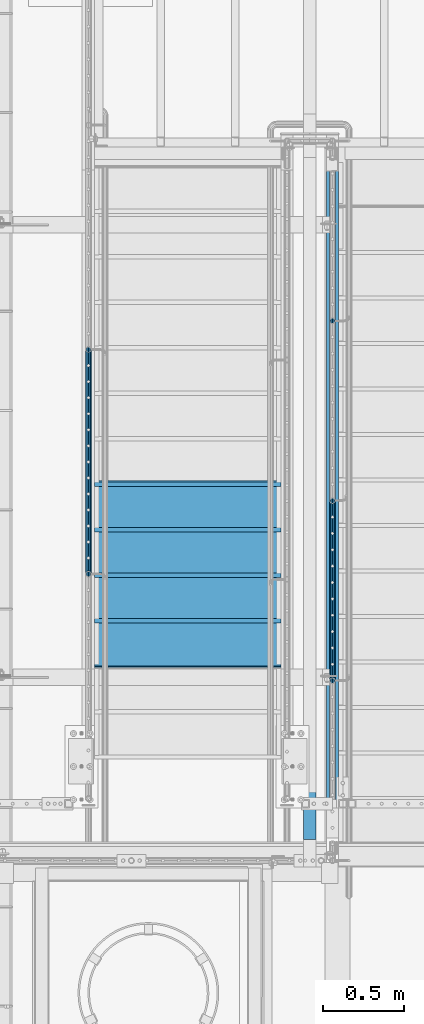
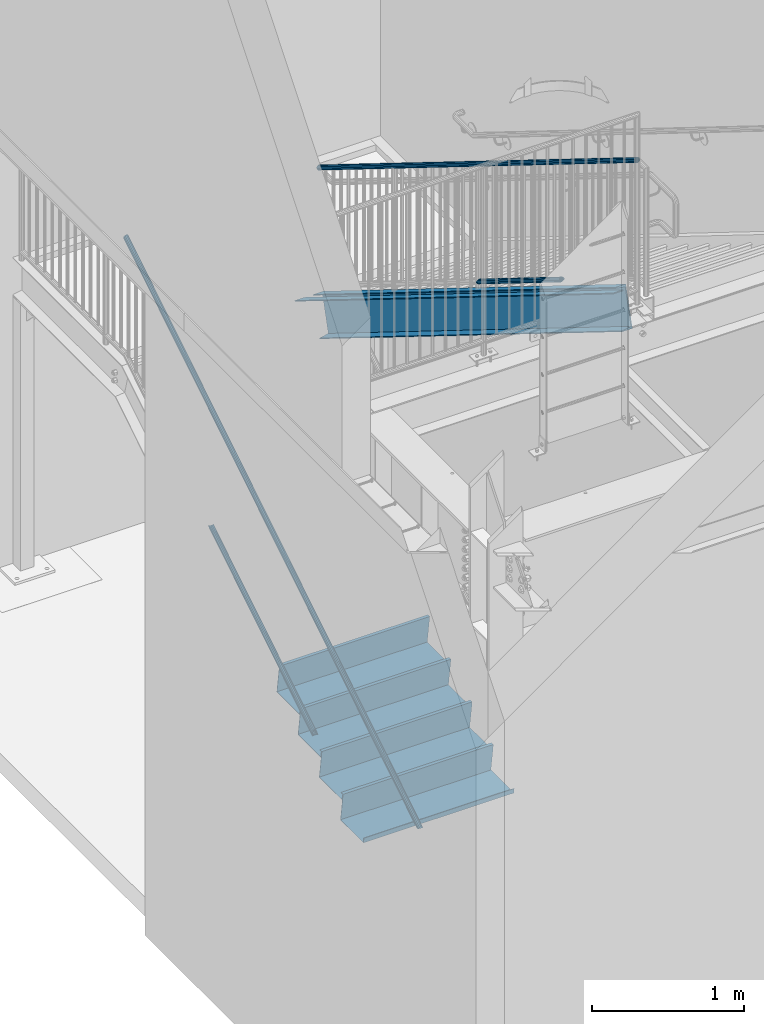
# One storey, part 1090 of 1763: 6 members, 4 beams, 5 elements without a shape of their own.
"""IFC2X3 building model written with IfcOpenShell, lengths in millimetres."""

from ifc_helpers import new_model, si_unit, frame, origin_with_axes, place, context, subcontext, project, spatial, faceted_brep, material, type_object, element, aggregate, save


model = new_model("IFC2X3")

# Units and contexts
model_context = context("Model", 3, precision=1e-05, world=origin_with_axes())
body_context = subcontext(model_context, "Body", "Model", "MODEL_VIEW")
ifc_project = project(units=[si_unit("LENGTHUNIT", "METRE", prefix="MILLI"), si_unit("AREAUNIT", "SQUARE_METRE"), si_unit("VOLUMEUNIT", "CUBIC_METRE"), si_unit("MASSUNIT", "GRAM", prefix="KILO"), si_unit("TIMEUNIT", "SECOND"), si_unit("PLANEANGLEUNIT", "RADIAN"), si_unit("SOLIDANGLEUNIT", "STERADIAN"), si_unit("THERMODYNAMICTEMPERATUREUNIT", "DEGREE_CELSIUS"), si_unit("LUMINOUSINTENSITYUNIT", "LUMEN")], contexts=[model_context])

# Site, building, storey
site_placement = place(None, origin_with_axes())
site = spatial("IfcSite", under=ifc_project, at=site_placement, CompositionType="ELEMENT")
building_placement = place(site_placement, origin_with_axes())
building = spatial("IfcBuilding", under=site, at=building_placement, Name="Undefined", CompositionType="ELEMENT")
storey_placement = place(building_placement, origin_with_axes())
storey = spatial("IfcBuildingStorey", under=building, at=storey_placement, Name="Undefined", CompositionType="ELEMENT", Elevation=0.0)

# Assembly, members
assembly_1_placement = place(storey_placement, origin_with_axes())
assembly_1 = element("IfcElementAssembly", 1, at=assembly_1_placement, inside=storey, Name="RAIL", AssemblyPlace="NOTDEFINED", PredefinedType="RIGID_FRAME")
ifc_material_1 = material(Name="STEEL/A513")
member_type_1 = type_object("IfcMemberType", PredefinedType="NOTDEFINED")
member_1_placement = place(assembly_1_placement, frame((-86778.5372736812, 33433.1733337026, 1304.42247650909), z_axis=(0.0, -0.527268387919125, 0.849698797869673), x_axis=(0.0, 0.849698797869672, 0.527268387919126)))
member_1 = element("IfcMember", 2, at=member_1_placement, type_object=member_type_1, material=ifc_material_1, Name="RAIL", context=body_context, shape_type="Brep", body=[
    faceted_brep([(1613.01194349174, -9.52499999999418, 16.4977839396925), (1609.88998428405, -9.5249999880034, 11.4667123895597), (1610.45199084115, -7.68349999999919, 13.3082123775639), (1609.30658025945, 1.01863406598568e-10, 15.3669999976082), (1611.59201302408, 7.27595761418343e-11, 19.0499999975946), (1610.45199083359, 7.68349999999919, 13.3082123775639), (1609.88998426917, 9.52500001198496, 11.4667123655781), (1613.01194349174, 9.52499999999418, 16.4977839396925), (1622.19051832688, 19.0500000000029, -2.38651409745216e-09), (1616.89126567261, 16.4977839420899, 9.52499999760767), (1605.07006171762, 16.4977839420899, -9.52500000234431), (1611.99478197705, 13.3082123799541, 7.68349999761631), (1609.64985805399, 15.3669999999984, -2.36468622460961e-09), (1602.45901078678, 13.3082123799541, -7.68350000234204), (1595.65897685763, 9.52500001198496, -11.4667123702893), (1592.53701763506, 9.52499999999418, -16.4977839444036), (1593.93555064269, 7.68349999999919, -13.3082123822751), (1590.23503787873, 0.0, -15.3670000023085), (1587.9496051141, 0.0, -19.0500000023021), (1595.65897684274, -9.5249999880034, -11.4667123942709), (1592.53701763506, -9.52499999999418, -16.4977839444036), (1593.93555065026, -7.68349999999919, -13.3082123822751), (1622.19051832273, -19.0499999880121, 1.89174897968769e-10), (1605.07006171762, -16.4977839420899, -9.52500000234431), (1616.89126567261, -16.4977839420899, 9.52499999760767), (1602.459010815, -13.3082123799541, -7.68350000234204), (1609.6498580822, -15.3669999999984, -2.36832420341671e-09), (1611.99478200527, -13.3082123799541, 7.68349999761631), (5.29925264853227, -16.4977839420899, -9.52499999999418), (9.17857482939507, -9.52499999999418, -16.497783942079), (0.0, 19.0500000000029, 0.0), (5.29925264853227, 16.4977839420899, -9.52499999999418), (17.1204566035267, 16.4977839420899, 9.5249999999578), (29.6535006860868, 9.52499999999418, 16.4977839420208), (34.240913207057, 2.60333763435483e-08, 19.0499999999156), (9.17857482939507, 9.52499999999418, -16.497783942079), (10.5985052970609, 0.0, -19.0499999999811), (12.8839380616882, 0.0, -15.3669999999911), (12.3005340283707, -9.5249999739608, -11.4667124059888), (11.7385274769949, -7.68349999999919, -13.3082123799504), (11.7385274934168, 7.68349999999919, -13.3082123799504), (12.3005340606833, 9.52500002602756, -11.466712353922), (10.1957363620568, 13.3082123799541, -7.68350000000282), (12.5406602851217, 15.3669999999984, -1.81898940354586e-11), (19.7315075523256, 13.3082123799541, 7.68349999995917), (26.5315414548058, 9.52500002602756, 11.4667123538638), (28.2549676843155, 7.68349999999919, 13.3082123798886), (31.9554804424188, 2.60333763435483e-08, 15.3669999999256), (28.2549676678937, -7.68349999999919, 13.3082123798922), (26.5315414871147, -9.5249999739608, 11.4667124059306), (29.6535006860868, -9.52499999999418, 16.4977839420208), (17.1204566035267, -16.4977839420899, 9.5249999999578), (0.0, -19.0500000000029, 0.0), (19.7315074910439, -13.3082123799541, 7.68349999995917), (12.5406602238363, -15.3669999999984, -1.81898940354586e-11), (10.195736300775, -13.3082123799541, -7.68349999999919)], [[[0, 1, 2, 3, 4]], [[4, 3, 5, 6, 7]], [[8, 9, 10]], [[7, 6, 11, 12, 13, 14, 15, 10, 9]], [[16, 17, 18, 15, 14]], [[19, 20, 18, 17, 21]], [[22, 23, 24]], [[24, 23, 20, 19, 25, 26, 27, 1, 0]], [[28, 29, 20, 23]], [[30, 31, 32]], [[33, 34, 4, 7]], [[32, 33, 7, 9]], [[30, 32, 9, 8]], [[31, 30, 8, 10]], [[35, 31, 10, 15]], [[36, 35, 15, 18]], [[29, 36, 18, 20]], [[37, 36, 29, 38, 39]], [[40, 41, 35, 36, 37]], [[32, 31, 35, 41, 42, 43, 44, 45, 33]], [[33, 45, 46, 47, 34]], [[34, 47, 48, 49, 50]], [[34, 50, 0, 4]], [[50, 51, 24, 0]], [[51, 52, 22, 24]], [[52, 28, 23, 22]], [[51, 28, 52]], [[50, 49, 53, 54, 55, 38, 29, 28, 51]], [[54, 53, 27, 26]], [[55, 54, 26, 25]], [[21, 39, 38, 55, 25, 19]], [[37, 39, 21, 17]], [[40, 37, 17, 16]], [[42, 41, 40, 16, 14, 13]], [[43, 42, 13, 12]], [[44, 43, 12, 11]], [[5, 46, 45, 44, 11, 6]], [[47, 46, 5, 3]], [[48, 47, 3, 2]], [[53, 49, 48, 2, 1, 27]]]),
])
member_2_placement = place(assembly_1_placement, frame((-86778.5372737124, 35928.2999984746, 3798.8875000154), z_axis=(0.0, 0.527268387919125, -0.849698797869673), x_axis=(0.0, -0.849698797869672, -0.527268387919127)))
member_2 = element("IfcMember", 3, at=member_2_placement, type_object=member_type_1, material=ifc_material_1, Name="RAIL", context=body_context, shape_type="Brep", body=[
    faceted_brep([(4.71409293822944e-08, -15.3669999999984, 0.0), (2.19023042815024, -13.3082123799541, 7.68349999998281), (4554.39948192647, -13.3082123799541, 7.68349999416932), (4558.67421239756, -15.3669999999984, -5.82258508075029e-09), (3.79359040603231, -7.68349999999919, 13.3082123799213), (4551.27016203296, -7.68349999999919, 13.3082123741169), (4.38046088934425, 0.0, 15.3669999999638), (4550.12475145536, 0.0, 15.3669999941631), (3.79359040603231, 7.68349999999919, 13.3082123799213), (4551.27016203296, 7.68349999999919, 13.3082123741169), (2.19023042815024, 13.3082123799541, 7.68349999998281), (4554.39948192647, 13.3082123799541, 7.68349999416932), (4.71409293822944e-08, 15.3669999999984, 0.0), (4558.67421239756, 15.3669999999984, -5.82258508075029e-09), (-2.19023049421958, 13.3082123799541, -7.68349999998463), (4562.94894286867, 13.3082123799541, -7.68350000581449), (-3.793590472098, 7.68349999999919, -13.308212379925), (4566.07826276218, 7.68349999999919, -13.3082123857621), (-4.38046095540631, 0.0, -15.3669999999674), (4567.22367333977, 0.0, -15.3670000058028), (-3.793590472098, -7.68349999999919, -13.308212379925), (4566.07826276218, -7.68349999999919, -13.3082123857621), (-2.19023049421958, -13.3082123799541, -7.68349999998463), (4562.94894286867, -13.3082123799541, -7.68350000581449), (0.0, -19.0500000000029, 0.0), (-2.71516176177829, -16.4977839420899, -9.52499999998145), (4563.97346504769, -16.4977839420899, -9.52500000581313), (4558.67421239756, -19.0500000000029, -5.82258508075029e-09), (-4.70279809798376, -9.52499999999418, -16.4977839420626), (4567.85278722973, -9.52499999999418, -16.4977839478997), (-5.43032349052737, 0.0, -19.0499999999593), (4569.27271769782, 0.0, -19.0500000058), (-4.70279809798376, 9.52499999999418, -16.4977839420626), (4567.85278722973, 9.52499999999418, -16.4977839478997), (-2.71516176177829, 16.4977839420899, -9.52499999998145), (4563.97346504769, 16.4977839420899, -9.52500000581313), (0.0, 19.0500000000029, 0.0), (4558.67421239756, 19.0500000000029, -5.82258508075029e-09), (2.71516169570896, 16.4977839420899, 9.52499999997963), (4553.37495974744, 16.4977839420899, 9.52499999416796), (4.70279803191806, 9.52499999999418, 16.497783942059), (4549.4956375654, 9.52499999999418, 16.4977839362509), (5.43032342445076, 0.0, 19.0499999999611), (4548.07570709731, 0.0, 19.0499999941567), (4.70279803191806, -9.52499999999418, 16.497783942059), (4549.4956375654, -9.52499999999418, 16.4977839362509), (2.71516169570896, -16.4977839420899, 9.52499999997963), (4553.37495974744, -16.4977839420899, 9.52499999416796)], [[[0, 1, 2, 3]], [[1, 4, 5, 2]], [[4, 6, 7, 5]], [[6, 8, 9, 7]], [[8, 10, 11, 9]], [[10, 12, 13, 11]], [[12, 14, 15, 13]], [[14, 16, 17, 15]], [[16, 18, 19, 17]], [[18, 20, 21, 19]], [[20, 22, 23, 21]], [[22, 0, 3, 23]], [[24, 25, 26, 27]], [[25, 28, 29, 26]], [[28, 30, 31, 29]], [[30, 32, 33, 31]], [[32, 34, 35, 33]], [[34, 36, 37, 35]], [[36, 38, 39, 37]], [[38, 40, 41, 39]], [[40, 42, 43, 41]], [[42, 44, 45, 43]], [[44, 46, 47, 45]], [[46, 24, 27, 47]], [[29, 31, 33, 35, 37, 39, 41, 43, 45, 47, 27, 26], [5, 7, 9, 11, 13, 15, 17, 19, 21, 23, 3, 2]], [[46, 44, 42, 40, 38, 36, 34, 32, 30, 28, 25, 24], [22, 20, 18, 16, 14, 12, 10, 8, 6, 4, 1, 0]]]),
])
aggregate(assembly_1, [member_1, member_2])

assembly_2_placement = place(storey_placement, origin_with_axes())
assembly_2 = element("IfcElementAssembly", 4, at=assembly_2_placement, inside=storey, Name="RAIL", AssemblyPlace="NOTDEFINED", PredefinedType="RIGID_FRAME")
member_3_placement = place(assembly_2_placement, frame((-85279.8721005617, 33883.5999999948, 4153.69374976892), z_axis=(0.0, 0.527450977296466, 0.849585467477524), x_axis=(0.0, -0.849585467029397, 0.527450978018281)))
member_3 = element("IfcMember", 5, at=member_3_placement, type_object=member_type_1, material=ifc_material_1, Name="RAIL", context=body_context, shape_type="Brep", body=[
    faceted_brep([(1291.34034242866, -9.52499999999418, 16.4977839424391), (1288.21688551118, -9.52499998686835, 11.4667123934378), (1288.7793628039, -7.68349999999919, 13.3082123803069), (1287.63424189633, 1.30967237055302e-10, 15.3670000003513), (1289.92077106115, 1.16415321826935e-10, 19.0500000003412), (1288.77936279561, 7.68349999999919, 13.3082123803069), (1288.21688549488, 9.52500001312001, 11.4667123671861), (1291.34034242866, 9.52499999999418, 16.4977839424391), (1300.516596015, 19.0500000000029, 3.78349795937538e-10), (1295.21868352965, 16.4977839420899, 9.52500000035798), (1283.39180853924, 16.4977839420899, -9.52499999961219), (1290.32115089875, 13.3082123799541, 7.68350000035934), (1287.97426286884, 15.3669999999984, 3.71073838323355e-10), (1280.78080507319, 13.3082123799541, -7.6834999996172), (1273.97905098428, 9.52500001312001, -11.466712366444), (1270.8555940505, 9.52499999999418, -16.4977839417006), (1272.25499910396, 7.68349999999919, -13.3082123795684), (1268.55355024514, 0.0, -15.3669999996055), (1266.26702108033, 0.0, -19.0499999996027), (1273.97905096798, -9.52499998686835, -11.4667123926956), (1270.8555940505, -9.52499999999418, -16.4977839417006), (1272.25499911225, -7.68349999999919, -13.3082123795648), (1300.51659600284, -19.0499999868771, 7.93079379945993e-09), (1283.39180853924, -16.4977839420899, -9.52499999961219), (1295.21868352965, -16.4977839420899, 9.52500000035798), (1280.78080510413, -13.3082123799541, -7.6834999996172), (1287.97426289978, -15.3669999999984, 3.71073838323355e-10), (1290.32115092969, -13.3082123799541, 7.68350000035934), (5.29791245489469, -16.4977839420899, -9.52499999998327), (9.17625355589189, -9.52499999999418, -16.4977839420644), (0.0, 19.0500000000029, 0.0), (5.29791245489469, 16.4977839420899, -9.52499999998327), (17.1247874453111, 16.4977839420899, 9.52499999999054), (29.6610019340442, 9.52499999999418, 16.4977839420753), (34.2495749042173, 1.31403794512153e-08, 19.0499999999811), (9.17625355589189, 9.52499999999418, -16.4977839420644), (10.5958249233954, 0.0, -19.0499999999665), (12.8823540882113, 0.0, -15.3669999999693), (12.2997104733658, -9.5249999868538, -11.466712393074), (11.7372331812621, -7.68349999999919, -13.3082123799286), (11.7372331895313, 7.68349999999919, -13.3082123799286), (12.2997104896785, 9.52500001313456, -11.4667123667932), (10.1954450863705, 13.3082123799541, -7.683499999981), (12.542333116282, 15.3669999999984, 7.27595761418343e-12), (19.735790911931, 13.3082123799541, 7.68349999999555), (26.5375450002612, 9.52500001313456, 11.4667123668078), (28.2615968811733, 7.68349999999919, 13.3082123799431), (31.9630457394014, 1.31403794512153e-08, 15.3669999999838), (28.2615968729006, -7.68349999999919, 13.3082123799431), (26.5375450165775, -9.5249999868538, 11.4667123930885), (29.6610019340442, -9.52499999999418, 16.4977839420753), (17.1247874453111, -16.4977839420899, 9.52499999999054), (0.0, -19.0500000000029, 0.0), (19.7357908810409, -13.3082123799541, 7.68349999999555), (12.5423330853882, -15.3669999999984, 3.63797880709171e-12), (10.195445055484, -13.3082123799541, -7.68349999998463)], [[[0, 1, 2, 3, 4]], [[4, 3, 5, 6, 7]], [[8, 9, 10]], [[7, 6, 11, 12, 13, 14, 15, 10, 9]], [[16, 17, 18, 15, 14]], [[19, 20, 18, 17, 21]], [[22, 23, 24]], [[24, 23, 20, 19, 25, 26, 27, 1, 0]], [[28, 29, 20, 23]], [[30, 31, 32]], [[33, 34, 4, 7]], [[32, 33, 7, 9]], [[30, 32, 9, 8]], [[31, 30, 8, 10]], [[35, 31, 10, 15]], [[36, 35, 15, 18]], [[29, 36, 18, 20]], [[37, 36, 29, 38, 39]], [[40, 41, 35, 36, 37]], [[32, 31, 35, 41, 42, 43, 44, 45, 33]], [[33, 45, 46, 47, 34]], [[34, 47, 48, 49, 50]], [[34, 50, 0, 4]], [[50, 51, 24, 0]], [[51, 52, 22, 24]], [[52, 28, 23, 22]], [[51, 28, 52]], [[50, 49, 53, 54, 55, 38, 29, 28, 51]], [[54, 53, 27, 26]], [[55, 54, 26, 25]], [[21, 39, 38, 55, 25, 19]], [[37, 39, 21, 17]], [[40, 37, 17, 16]], [[42, 41, 40, 16, 14, 13]], [[43, 42, 13, 12]], [[44, 43, 12, 11]], [[5, 46, 45, 44, 11, 6]], [[47, 46, 5, 3]], [[48, 47, 3, 2]], [[53, 49, 48, 2, 1, 27]]]),
])
member_4_placement = place(assembly_2_placement, frame((-85279.8721005167, 31788.0999981694, 6400.79999979009), z_axis=(0.0, -0.527450978018281, -0.849585467029397), x_axis=(0.0, 0.849585467029409, -0.527450978018262)))
member_4 = element("IfcMember", 6, at=member_4_placement, type_object=member_type_1, material=ifc_material_1, Name="RAIL", context=body_context, shape_type="Brep", body=[
    faceted_brep([(4.71409293822944e-08, -15.3669999999984, 0.0), (2.19112329075506, -13.3082123799541, 7.68349999999191), (4935.18511077163, -13.3082123799541, 7.68350000142891), (4932.99398759136, -15.3669999999984, 1.42244971357286e-09), (3.79513678437797, -7.68349999999919, 13.3082123799395), (4936.78912426524, -7.68349999999919, 13.3082123813874), (4.38224647105744, 0.0, 15.3669999999802), (4937.37623395191, 0.0, 15.3670000014281), (3.79513678437797, 7.68349999999919, 13.3082123799395), (4936.78912426524, 7.68349999999919, 13.3082123813874), (2.19112329075506, 13.3082123799541, 7.68349999999191), (4935.18511077163, 13.3082123799541, 7.68350000142891), (4.71409293822944e-08, 15.3669999999984, 0.0), (4932.99398759136, 15.3669999999984, 1.42244971357286e-09), (-2.19112306985699, 13.3082123799541, -7.68349999998827), (4930.80286441108, 13.3082123799541, -7.68349999858037), (-3.79513656348718, 7.68349999999919, -13.3082123799322), (4929.19885091748, 7.68349999999919, -13.3082123785352), (-4.38224625016301, 0.0, -15.3669999999765), (4928.61174123081, 0.0, -15.3669999985868), (-3.79513656348718, -7.68349999999919, -13.3082123799322), (4929.19885091748, -7.68349999999919, -13.3082123785352), (-2.19112306985699, -13.3082123799541, -7.68349999998827), (4930.80286441108, -13.3082123799541, -7.68349999858037), (0.0, -19.0500000000029, 0.0), (-2.71626829489105, -16.4977839420899, -9.52499999998327), (4930.27771918606, -16.4977839420899, -9.52499999858264), (4932.99398759136, -19.0500000000029, 1.42244971357286e-09), (-4.70471477459068, -9.52499999999418, -16.4977839420681), (4928.28927270639, -9.52499999999418, -16.4977839406783), (-5.4325367002275, 0.0, -19.0499999999702), (4927.56145078075, 0.0, -19.0499999985841), (-4.70471477459068, 9.52499999999418, -16.4977839420681), (4928.28927270639, 9.52499999999418, -16.4977839406783), (-2.71626829489105, 16.4977839420899, -9.52499999998327), (4930.27771918606, 16.4977839420899, -9.52499999858264), (0.0, 19.0500000000029, 0.0), (4932.99398759136, 19.0500000000029, 1.42244971357286e-09), (2.71626851578549, 16.4977839420899, 9.52499999999054), (4935.71025599666, 16.4977839420899, 9.5250000014239), (4.70471499548876, 9.52499999999418, 16.4977839420717), (4937.69870247633, 9.52499999999418, 16.4977839435232), (5.43253692112557, 0.0, 19.0499999999738), (4938.42652440196, 0.0, 19.0500000014326), (4.70471499548876, -9.52499999999418, 16.4977839420717), (4937.69870247633, -9.52499999999418, 16.4977839435232), (2.71626851578549, -16.4977839420899, 9.52499999999054), (4935.71025599666, -16.4977839420899, 9.5250000014239)], [[[0, 1, 2, 3]], [[1, 4, 5, 2]], [[4, 6, 7, 5]], [[6, 8, 9, 7]], [[8, 10, 11, 9]], [[10, 12, 13, 11]], [[12, 14, 15, 13]], [[14, 16, 17, 15]], [[16, 18, 19, 17]], [[18, 20, 21, 19]], [[20, 22, 23, 21]], [[22, 0, 3, 23]], [[24, 25, 26, 27]], [[25, 28, 29, 26]], [[28, 30, 31, 29]], [[30, 32, 33, 31]], [[32, 34, 35, 33]], [[34, 36, 37, 35]], [[36, 38, 39, 37]], [[38, 40, 41, 39]], [[40, 42, 43, 41]], [[42, 44, 45, 43]], [[44, 46, 47, 45]], [[46, 24, 27, 47]], [[29, 31, 33, 35, 37, 39, 41, 43, 45, 47, 27, 26], [5, 7, 9, 11, 13, 15, 17, 19, 21, 23, 3, 2]], [[46, 44, 42, 40, 38, 36, 34, 32, 30, 28, 25, 24], [22, 20, 18, 16, 14, 12, 10, 8, 6, 4, 1, 0]]]),
])
aggregate(assembly_2, [member_3, member_4])

# Assembly, member
assembly_3_placement = place(storey_placement, origin_with_axes())
assembly_3 = element("IfcElementAssembly", 7, at=assembly_3_placement, inside=storey, Name="STRINGER", AssemblyPlace="NOTDEFINED", PredefinedType="RIGID_FRAME")
ifc_material_2 = material(Name="STEEL/A36")
member_type_2 = type_object("IfcMemberType", Name="C12X20.7", PredefinedType="NOTDEFINED")
member_5_placement = place(assembly_3_placement, frame((-85279.8721013125, 35913.2032370951, 2653.41067476985), z_axis=(0.0, 0.527450977296466, 0.849585467477524), x_axis=(0.0, -0.849585467029397, 0.527450978018281)))
member_5 = element("IfcMember", 8, at=member_5_placement, type_object=member_type_2, material=ifc_material_2, Name="STRINGER", ObjectType="C12X20.7", context=body_context, shape_type="Brep", body=[
    faceted_brep([(-86.9205864272517, -38.1000000000058, -152.4), (-85.109016492308, -38.1000000000058, -146.04746), (-81.8658825708844, 30.1625000000058, -134.6749275), (-5.05470164173312, 30.1625000000058, 134.6749275), (-1.81156772031682, -38.1000000000058, 146.04746), (0.0, -38.1000000000004, 152.4), (0.0, 38.1000000000004, 152.4), (-86.9205864272517, 38.1000000000058, -152.4), (4692.21331760864, -38.1000000000058, 152.400000002923), (4692.21331760864, 38.1000000000058, 152.400000002923), (4605.29272863781, 38.1000000000058, -152.399999996647), (4605.29272863781, -38.1000000000058, -152.399999996647), (4607.10429857961, -38.1000000000058, -146.047459996655), (4610.34743251331, 30.1625000000058, -134.674927496671), (4687.15861373315, 30.1625000000058, 134.674927502947), (4690.40174766684, -38.1000000000058, 146.04746000293)], [[[0, 1, 2, 3, 4, 5, 6, 7]], [[6, 5, 8, 9]], [[7, 6, 9, 10]], [[0, 7, 10, 11]], [[1, 0, 11, 12]], [[2, 1, 12, 13]], [[3, 2, 13, 14]], [[4, 3, 14, 15]], [[5, 4, 15, 8]], [[14, 13, 12, 11, 10, 9, 8, 15]]]),
])
aggregate(assembly_3, [member_5])

assembly_4_placement = place(storey_placement, origin_with_axes())
assembly_4 = element("IfcElementAssembly", 9, at=assembly_4_placement, inside=storey, Name="ref.", AssemblyPlace="NOTDEFINED", PredefinedType="NOTDEFINED")
ifc_material_3 = material()
member_type_3 = type_object("IfcMemberType", PredefinedType="NOTDEFINED")
member_6_placement = place(assembly_4_placement, frame((-85419.6372736932, 35991.9121091871, 2780.19006615586), z_axis=(1.0, 0.0, 0.0), x_axis=(0.0, -0.849585467029397, 0.527450978018281)))
member_6 = element("IfcMember", 10, at=member_6_placement, type_object=member_type_3, material=ifc_material_3, Name="ref.", context=body_context, shape_type="Brep", body=[
    faceted_brep([(0.0, 3.17500000000018, -38.0999999999985), (0.0, 3.17500000000018, 38.0999999999985), (4932.99398621066, 3.17499999666325, 38.1000000000058), (4932.99398621066, 3.17499999666325, -38.1000000000058), (0.0, -3.17500000000018, 38.0999999999985), (4932.99398621068, -3.17500000332439, 38.1000000000058), (0.0, -3.17500000000018, -38.0999999999985), (4932.99398621068, -3.17500000332439, -38.1000000000058)], [[[0, 1, 2, 3]], [[1, 4, 5, 2]], [[4, 6, 7, 5]], [[6, 0, 3, 7]], [[5, 7, 3, 2]], [[6, 4, 1, 0]]]),
])
aggregate(assembly_4, [member_6])

# Assembly, beams
assembly_5_placement = place(storey_placement, origin_with_axes())
assembly_5 = element("IfcElementAssembly", 11, at=assembly_5_placement, inside=storey, Name="STRINGER", AssemblyPlace="NOTDEFINED", PredefinedType="RIGID_FRAME")
beam_type = type_object("IfcBeamType", PredefinedType="NOTDEFINED")
beam_1_placement = place(assembly_5_placement, frame((-86168.937273734, 33997.899999984, 1516.85625000058), z_axis=(1.0, 0.0, 0.0), x_axis=(0.0, -1.0, 0.0)))
beam_1 = element("IfcBeam", 12, at=beam_1_placement, type_object=beam_type, material=ifc_material_2, Name="TREAD", context=body_context, shape_type="Brep", body=[
    faceted_brep([(0.0, -1.58749999999964, -571.5), (0.0, -1.58749999999964, 571.5), (0.0, 1.58749999999964, 571.5), (0.0, 1.58749999999964, -571.5), (21.7259680928437, 1.58749999999998, 571.5), (21.7259680928437, 1.58749999999998, -571.5), (25.3999996185303, -1.58749999999998, -571.5), (25.3999996185303, -1.58749999999998, 571.5), (-11.1162812923722, 225.765173339844, 571.5), (-11.1162812923722, 225.765173339844, -571.5), (-7.44224977493286, 222.590173339844, -571.5), (-7.44224977493286, 222.590173339844, 571.5), (293.683722205024, 225.765173339844, 571.5), (293.683722205024, 225.765173339844, -571.5), (290.939971923828, 222.590173339844, -571.5), (290.939971923828, 222.590173339844, 571.5), (299.604174562657, 185.35280002685, 571.5), (299.604174562657, 185.35280002685, -571.5), (296.462707519531, 184.892572021484, 571.5), (296.462707519531, 184.892572021484, -571.5)], [[[0, 1, 2, 3]], [[3, 2, 4, 5]], [[1, 0, 6, 7]], [[5, 4, 8, 9]], [[7, 6, 10, 11]], [[9, 8, 12, 13]], [[11, 10, 14, 15]], [[13, 12, 16, 17]], [[12, 8, 4, 2, 1, 7, 11, 15, 18, 16]], [[15, 14, 19, 18]], [[14, 10, 6, 0, 3, 5, 9, 13, 17, 19]], [[18, 19, 17, 16]]]),
])
beam_2_placement = place(assembly_5_placement, frame((-86168.937273734, 33718.499999984, 1343.47857142915), z_axis=(1.0, 0.0, 0.0), x_axis=(0.0, -1.0, 0.0)))
beam_2 = element("IfcBeam", 13, at=beam_2_placement, type_object=beam_type, material=ifc_material_2, Name="TREAD", context=body_context, shape_type="Brep", body=[
    faceted_brep([(0.0, -1.58749999999964, -571.5), (0.0, -1.58749999999964, 571.5), (0.0, 1.58749999999964, 571.5), (0.0, 1.58749999999964, -571.5), (21.7259680928437, 1.58749999999998, 571.5), (21.7259680928437, 1.58749999999998, -571.5), (25.3999996185303, -1.58749999999998, -571.5), (25.3999996185303, -1.58749999999998, 571.5), (-11.1162812923722, 225.765173339844, 571.5), (-11.1162812923722, 225.765173339844, -571.5), (-7.44224977493286, 222.590173339844, -571.5), (-7.44224977493286, 222.590173339844, 571.5), (293.683722205024, 225.765173339844, 571.5), (293.683722205024, 225.765173339844, -571.5), (290.939971923828, 222.590173339844, -571.5), (290.939971923828, 222.590173339844, 571.5), (299.604174562657, 185.35280002685, 571.5), (299.604174562657, 185.35280002685, -571.5), (296.462707519531, 184.892572021484, 571.5), (296.462707519531, 184.892572021484, -571.5)], [[[0, 1, 2, 3]], [[3, 2, 4, 5]], [[1, 0, 6, 7]], [[5, 4, 8, 9]], [[7, 6, 10, 11]], [[9, 8, 12, 13]], [[11, 10, 14, 15]], [[13, 12, 16, 17]], [[12, 8, 4, 2, 1, 7, 11, 15, 18, 16]], [[15, 14, 19, 18]], [[14, 10, 6, 0, 3, 5, 9, 13, 17, 19]], [[18, 19, 17, 16]]]),
])
beam_3_placement = place(assembly_5_placement, frame((-86168.937273734, 33439.099999984, 1170.10089285772), z_axis=(1.0, 0.0, 0.0), x_axis=(0.0, -1.0, 0.0)))
beam_3 = element("IfcBeam", 14, at=beam_3_placement, type_object=beam_type, material=ifc_material_2, Name="TREAD", context=body_context, shape_type="Brep", body=[
    faceted_brep([(0.0, -1.58749999999964, -571.5), (0.0, -1.58749999999964, 571.5), (0.0, 1.58749999999964, 571.5), (0.0, 1.58749999999964, -571.5), (21.7259680928437, 1.58749999999998, 571.5), (21.7259680928437, 1.58749999999998, -571.5), (25.3999996185303, -1.58749999999998, -571.5), (25.3999996185303, -1.58749999999998, 571.5), (-11.1162812923722, 225.765173339844, 571.5), (-11.1162812923722, 225.765173339844, -571.5), (-7.44224977493286, 222.590173339844, -571.5), (-7.44224977493286, 222.590173339844, 571.5), (293.683722205024, 225.765173339844, 571.5), (293.683722205024, 225.765173339844, -571.5), (290.939971923828, 222.590173339844, -571.5), (290.939971923828, 222.590173339844, 571.5), (299.604174562657, 185.35280002685, 571.5), (299.604174562657, 185.35280002685, -571.5), (296.462707519531, 184.892572021484, 571.5), (296.462707519531, 184.892572021484, -571.5)], [[[0, 1, 2, 3]], [[3, 2, 4, 5]], [[1, 0, 6, 7]], [[5, 4, 8, 9]], [[7, 6, 10, 11]], [[9, 8, 12, 13]], [[11, 10, 14, 15]], [[13, 12, 16, 17]], [[12, 8, 4, 2, 1, 7, 11, 15, 18, 16]], [[15, 14, 19, 18]], [[14, 10, 6, 0, 3, 5, 9, 13, 17, 19]], [[18, 19, 17, 16]]]),
])
beam_4_placement = place(assembly_5_placement, frame((-86168.937273734, 33159.699999984, 996.723214286291), z_axis=(1.0, 0.0, 0.0), x_axis=(0.0, -1.0, 0.0)))
beam_4 = element("IfcBeam", 15, at=beam_4_placement, type_object=beam_type, material=ifc_material_2, Name="TREAD", context=body_context, shape_type="Brep", body=[
    faceted_brep([(0.0, -1.58749999999964, -571.5), (0.0, -1.58749999999964, 571.5), (0.0, 1.58749999999964, 571.5), (0.0, 1.58749999999964, -571.5), (21.7259680928437, 1.58749999999998, 571.5), (21.7259680928437, 1.58749999999998, -571.5), (25.3999996185303, -1.58749999999998, -571.5), (25.3999996185303, -1.58749999999998, 571.5), (-11.1162812923722, 225.765173339844, 571.5), (-11.1162812923722, 225.765173339844, -571.5), (-7.44224977493286, 222.590173339844, -571.5), (-7.44224977493286, 222.590173339844, 571.5), (293.683722205024, 225.765173339844, 571.5), (293.683722205024, 225.765173339844, -571.5), (290.939971923828, 222.590173339844, -571.5), (290.939971923828, 222.590173339844, 571.5), (299.604174562657, 185.35280002685, 571.5), (299.604174562657, 185.35280002685, -571.5), (296.462707519531, 184.892572021484, 571.5), (296.462707519531, 184.892572021484, -571.5)], [[[0, 1, 2, 3]], [[3, 2, 4, 5]], [[1, 0, 6, 7]], [[5, 4, 8, 9]], [[7, 6, 10, 11]], [[9, 8, 12, 13]], [[11, 10, 14, 15]], [[13, 12, 16, 17]], [[12, 8, 4, 2, 1, 7, 11, 15, 18, 16]], [[15, 14, 19, 18]], [[14, 10, 6, 0, 3, 5, 9, 13, 17, 19]], [[18, 19, 17, 16]]]),
])
aggregate(assembly_5, [beam_1, beam_2, beam_3, beam_4])

save(model, "model.ifc")
